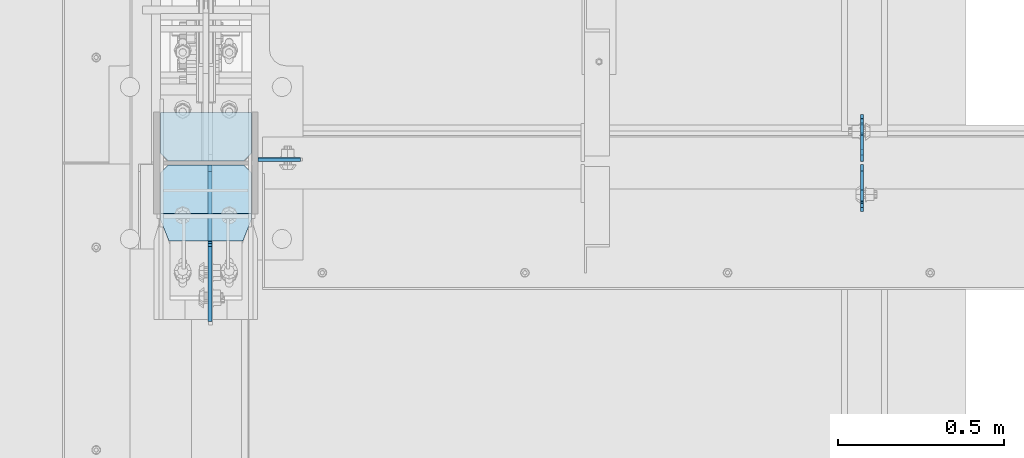
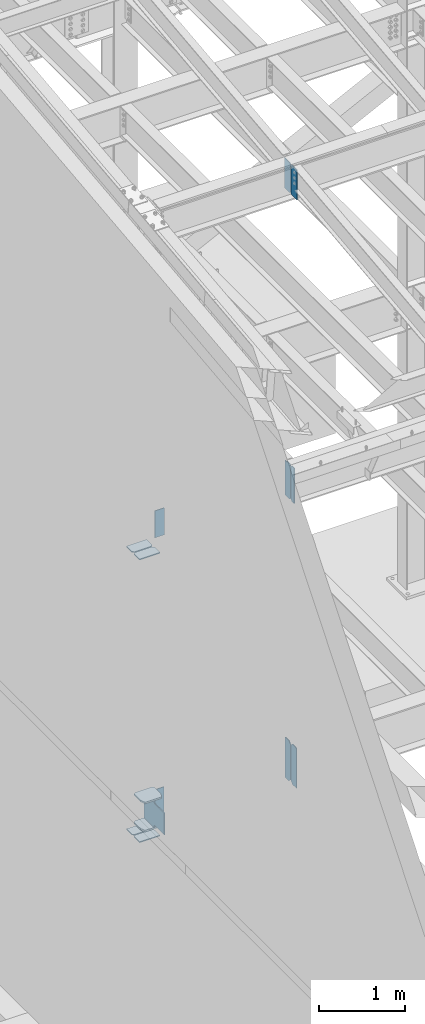
# One storey, part 1022 of 1179: 15 plates, 4 elements without a shape of their own.
"""IFC2X3 building model written with IfcOpenShell, lengths in millimetres."""

from ifc_helpers import new_model, si_unit, frame, origin_with_axes, place, context, subcontext, project, spatial, faceted_brep, material, type_object, element, aggregate, save


model = new_model("IFC2X3")

# Units and contexts
model_context = context("Model", 3, precision=1e-05, world=origin_with_axes())
body_context = subcontext(model_context, "Body", "Model", "MODEL_VIEW")
ifc_project = project(units=[si_unit("LENGTHUNIT", "METRE", prefix="MILLI"), si_unit("AREAUNIT", "SQUARE_METRE"), si_unit("VOLUMEUNIT", "CUBIC_METRE"), si_unit("MASSUNIT", "GRAM", prefix="KILO"), si_unit("TIMEUNIT", "SECOND"), si_unit("PLANEANGLEUNIT", "RADIAN"), si_unit("SOLIDANGLEUNIT", "STERADIAN"), si_unit("THERMODYNAMICTEMPERATUREUNIT", "DEGREE_CELSIUS"), si_unit("LUMINOUSINTENSITYUNIT", "LUMEN")], contexts=[model_context])

# Site, building, storey
site_placement = place(None, origin_with_axes())
site = spatial("IfcSite", under=ifc_project, at=site_placement, CompositionType="ELEMENT")
building_placement = place(site_placement, origin_with_axes())
building = spatial("IfcBuilding", under=site, at=building_placement, Name="Undefined", CompositionType="ELEMENT")
storey_placement = place(building_placement, origin_with_axes())
storey = spatial("IfcBuildingStorey", under=building, at=storey_placement, Name="Undefined", CompositionType="ELEMENT", Elevation=0.0)

# Assembly, plate
assembly_1_placement = place(storey_placement, origin_with_axes())
assembly_1 = element("IfcElementAssembly", 1, at=assembly_1_placement, inside=storey, Name="BEAM", AssemblyPlace="NOTDEFINED", PredefinedType="RIGID_FRAME")
ifc_material_1 = material(Name="STEEL/A36")
plate_type_1 = type_object("IfcPlateType", PredefinedType="NOTDEFINED")
plate_1_placement = place(assembly_1_placement, frame((2405.06200008392, 27055.7625, 7497.7625), z_axis=(0.0, 0.0, 1.0), x_axis=(0.0, 1.0, 0.0)))
plate_1 = element("IfcPlate", 2, at=plate_1_placement, type_object=plate_type_1, material=ifc_material_1, Name="PLATE", context=body_context, shape_type="Brep", body=[
    faceted_brep([(77.7874999999985, -4.76250000000073, 498.475), (77.7874999999985, -4.76250000000073, 496.887499809264), (77.7874999999985, 4.76250000000073, 496.887499809264), (77.7874999999985, 4.76250000000073, 498.475), (78.7542299225861, -4.76250000000073, 492.027420291219), (78.7542299225861, 4.76250000000073, 492.027420291219), (81.5072438230636, -4.76250000000073, 487.907243823065), (81.5072438230636, 4.76250000000073, 487.907243823065), (85.6274202912173, -4.76250000000073, 485.154229922587), (85.6274202912173, 4.76250000000073, 485.154229922587), (90.4874998092637, -4.76250000000073, 484.187499999999), (90.4874998092637, 4.76250000000073, 484.187499999999), (127.000006866454, -4.76249999999982, 484.1875), (127.000004873051, 4.76249999999982, 484.1875), (0.0, -4.76250000000073, 479.425006866455), (19.0499992370605, -4.76250000000073, 498.475006103516), (19.0499992370605, 4.76250000000073, 498.475006103516), (0.0, 4.76250000000073, 479.425006866455), (0.0, -4.76250000000073, 19.0499992370605), (0.0, 4.76250000000073, 19.0499992370605), (19.0499992370605, -4.76250000000073, 0.0), (19.0499992370605, 4.76250000000073, 0.0), (127.0, -4.76250000000073, 0.0), (127.0, 4.76250000000073, 0.0)], [[[0, 1, 2, 3]], [[4, 5, 2, 1]], [[6, 7, 5, 4]], [[8, 9, 7, 6]], [[10, 11, 9, 8]], [[12, 13, 11, 10]], [[14, 15, 16, 17]], [[18, 14, 17, 19]], [[20, 18, 19, 21]], [[22, 20, 21, 23]], [[8, 6, 4, 1, 0, 15, 14, 18, 20, 22, 12, 10]], [[16, 15, 0, 3]], [[23, 21, 19, 17, 16, 3, 2, 5, 7, 9, 11, 13]], [[22, 23, 13, 12]]]),
])

# Assembly, plates
assembly_2_placement = place(storey_placement, origin_with_axes())
assembly_2 = element("IfcElementAssembly", 3, at=assembly_2_placement, inside=storey, Name="COLUMN", AssemblyPlace="NOTDEFINED", PredefinedType="RIGID_FRAME")
plate_2_placement = place(assembly_2_placement, frame((588.962500000001, 27060.525, 7975.6), z_axis=(1.0, 0.0, 0.0), x_axis=(0.0, 0.0, -1.0)))
plate_2 = element("IfcPlate", 4, at=plate_2_placement, type_object=plate_type_1, material=ifc_material_1, Name="PLATE", context=body_context, shape_type="Brep", body=[
    faceted_brep([(0.0, -4.76249999999709, 0.0), (0.0, -4.76249999999709, 127.0), (0.0, 4.76249999999709, 127.0), (0.0, 4.76249999999709, 0.0), (381.0, -4.76249999999709, 127.0), (381.0, 4.76249999999709, 127.0), (381.0, -4.76249999999999, 8.66293703438714e-11), (381.0, 4.76249999999999, 8.66293703438714e-11)], [[[0, 1, 2, 3]], [[1, 4, 5, 2]], [[4, 6, 7, 5]], [[6, 0, 3, 7]], [[5, 7, 3, 2]], [[6, 4, 1, 0]]]),
])
plate_3_placement = place(assembly_2_placement, frame((588.962500000001, 27062.1125, 4038.6), z_axis=(1.0, 0.0, 0.0), x_axis=(0.0, 0.0, -1.0)))
plate_3 = element("IfcPlate", 5, at=plate_3_placement, type_object=plate_type_1, material=ifc_material_1, Name="PLATE", context=body_context, shape_type="Brep", body=[
    faceted_brep([(0.0, -4.76249999999709, 0.0), (0.0, -4.76249999999709, 127.0), (0.0, 4.76249999999709, 127.0), (0.0, 4.76249999999709, 0.0), (457.200012207031, -4.76250000000073, 127.0), (457.200012207031, 4.76250000000073, 127.0), (457.200012207031, -4.76250000000073, 0.0), (457.200012207031, 4.76250000000073, 0.0)], [[[0, 1, 2, 3]], [[1, 4, 5, 2]], [[4, 6, 7, 5]], [[6, 0, 3, 7]], [[5, 7, 3, 2]], [[6, 4, 1, 0]]]),
])

assembly_3_placement = place(storey_placement, origin_with_axes())
assembly_3 = element("IfcElementAssembly", 6, at=assembly_3_placement, inside=storey, Name="BEAM", AssemblyPlace="NOTDEFINED", PredefinedType="RIGID_FRAME")
plate_4_placement = place(assembly_3_placement, frame((2405.06185359955, 27044.65, 3509.9625), z_axis=(0.0, 0.0, 1.0), x_axis=(0.0, -1.0, 0.0)))
plate_4 = element("IfcPlate", 7, at=plate_4_placement, type_object=plate_type_1, material=ifc_material_1, Name="PLATE", context=body_context, shape_type="Brep", body=[
    faceted_brep([(108.916729922588, -4.76250000000073, 568.227420481955), (108.916729922588, 4.76250000000073, 568.227420481955), (108.265773383217, 4.76250000000073, 571.5), (108.265773383217, -4.76250000000073, 571.5), (111.669743823066, -4.76250000000073, 564.107244013801), (111.669743823066, 4.76250000000073, 564.107244013801), (115.789920291219, -4.76250000000073, 561.354230113323), (115.789920291219, 4.76250000000073, 561.354230113323), (120.649999809266, -4.76250000000073, 560.387500190735), (120.649999809266, 4.76250000000073, 560.387500190735), (127.000006866456, -4.76250000000073, 560.387500190735), (127.000004873054, 4.76250000000073, 560.387500190735), (0.0, -4.76250000000073, 536.575000762939), (34.9249992370605, -4.76250000000073, 571.5), (34.9249992370605, 4.76250000000073, 571.5), (0.0, 4.76250000000073, 536.575000762939), (0.0, -4.76250000000073, 34.9249999999993), (0.0, 4.76250000000073, 34.9249999999993), (34.9249992370715, -4.76249999996799, 0.0), (34.9249992370678, 4.76250000003347, 0.0), (127.0, -4.76250000000073, 0.0), (127.0, 4.76250000000073, 0.0)], [[[0, 1, 2, 3]], [[4, 5, 1, 0]], [[6, 7, 5, 4]], [[8, 9, 7, 6]], [[10, 11, 9, 8]], [[12, 13, 14, 15]], [[16, 12, 15, 17]], [[18, 16, 17, 19]], [[20, 18, 19, 21]], [[6, 4, 0, 3, 13, 12, 16, 18, 20, 10, 8]], [[14, 13, 3, 2]], [[21, 19, 17, 15, 14, 2, 1, 5, 7, 9, 11]], [[20, 21, 11, 10]]]),
])
plate_5_placement = place(assembly_3_placement, frame((2405.06185359955, 27057.35, 3509.9625), z_axis=(0.0, 0.0, 1.0), x_axis=(0.0, 1.0, 0.0)))
plate_5 = element("IfcPlate", 8, at=plate_5_placement, type_object=plate_type_1, material=ifc_material_1, Name="PLATE", context=body_context, shape_type="Brep", body=[
    faceted_brep([(108.916729922588, -4.76250000000073, 568.227420481955), (108.916729922588, 4.76250000000073, 568.227420481955), (108.265773383217, 4.76250000000073, 571.5), (108.265773383217, -4.76250000000073, 571.5), (111.669743823066, -4.76250000000073, 564.107244013801), (111.669743823066, 4.76250000000073, 564.107244013801), (115.789920291219, -4.76250000000073, 561.354230113323), (115.789920291219, 4.76250000000073, 561.354230113323), (120.649999809266, -4.76250000000073, 560.387500190735), (120.649999809266, 4.76250000000073, 560.387500190735), (127.000006866456, -4.76250000000073, 560.387500190735), (127.000004873054, 4.76250000000073, 560.387500190735), (0.0, -4.76250000000073, 536.575000762939), (34.9249992370605, -4.76250000000073, 571.5), (34.9249992370605, 4.76250000000073, 571.5), (0.0, 4.76250000000073, 536.575000762939), (0.0, -4.76250000000073, 34.9249999999993), (0.0, 4.76250000000073, 34.9249999999993), (34.9249992370715, -4.76249999996799, 0.0), (34.9249992370678, 4.76250000003347, 0.0), (127.0, -4.76250000000073, 0.0), (127.0, 4.76250000000073, 0.0)], [[[0, 1, 2, 3]], [[4, 5, 1, 0]], [[6, 7, 5, 4]], [[8, 9, 7, 6]], [[10, 11, 9, 8]], [[12, 13, 14, 15]], [[16, 12, 15, 17]], [[18, 16, 17, 19]], [[20, 18, 19, 21]], [[6, 4, 0, 3, 13, 12, 16, 18, 20, 10, 8]], [[14, 13, 3, 2]], [[21, 19, 17, 15, 14, 2, 1, 5, 7, 9, 11]], [[20, 21, 11, 10]]]),
])
aggregate(assembly_3, [plate_4, plate_5])

# Plate
plate_type_2 = type_object("IfcPlateType", PredefinedType="NOTDEFINED")
plate_6_placement = place(assembly_1_placement, frame((2405.06200008392, 27046.2375, 7497.7625), z_axis=(0.0, 0.0, 1.0), x_axis=(0.0, -1.0, 0.0)))
plate_6 = element("IfcPlate", 9, at=plate_6_placement, type_object=plate_type_2, material=ifc_material_1, Name="PLATE", context=body_context, shape_type="Brep", body=[
    faceted_brep([(0.0, -4.76250000000073, 19.0499992370605), (0.0, -4.76250000000073, 479.425006866455), (0.0, 4.76250000000073, 479.425006866455), (0.0, 4.76250000000073, 19.0499992370605), (19.0499992370605, -4.76250000000073, 498.475006103516), (19.0499992370605, 4.76250000000073, 498.475006103516), (76.1999969482422, -4.76250000000073, 498.475006103516), (76.1999969482422, 4.76250000000073, 498.475006103516), (76.1999999999971, -4.76249999999999, 0.0), (76.1999999999971, 4.76249999999999, 0.0), (19.0499992370605, -4.76250000000073, 0.0), (19.0499992370605, 4.76250000000073, 0.0)], [[[0, 1, 2, 3]], [[1, 4, 5, 2]], [[4, 6, 7, 5]], [[6, 8, 9, 7]], [[8, 10, 11, 9]], [[10, 0, 3, 11]], [[5, 7, 9, 11, 3, 2]], [[10, 8, 6, 4, 1, 0]]]),
])

aggregate(assembly_1, [plate_6, plate_1])

# Assembly, plates
assembly_4_placement = place(storey_placement, origin_with_axes())
assembly_4 = element("IfcElementAssembly", 10, at=assembly_4_placement, inside=storey, Name="BEAM", AssemblyPlace="NOTDEFINED", PredefinedType="RIGID_FRAME")
plate_type_3 = type_object("IfcPlateType", PredefinedType="NOTDEFINED")
plate_7_placement = place(assembly_4_placement, frame((2405.06200008392, 27045.4437499701, 11823.3031250357), z_axis=(0.0, 0.0, 1.0), x_axis=(0.0, -1.0, 0.0)))
plate_7 = element("IfcPlate", 11, at=plate_7_placement, type_object=plate_type_3, material=ifc_material_1, Name="PLATE", context=body_context, shape_type="Brep", body=[
    faceted_brep([(-1.81898940354586e-12, -4.76249999999345, 17.4624996185303), (0.0, -4.76250000000073, 407.98750038147), (0.0, 4.76250000000073, 407.98750038147), (1.81898940354586e-12, 4.76250000000073, 17.4624996185303), (17.4624996185303, -4.76250000000073, 425.450000000001), (17.4624996185303, 4.76250000000073, 425.450000000001), (139.699999999997, -4.76250000000073, 425.450000000001), (139.699999999997, 4.76250000000073, 425.450000000001), (139.7, -4.76249999999982, 0.0), (139.7, 4.76249999999982, 0.0), (17.4624996185157, -4.76250000000073, 0.0), (17.4624996185212, 4.76249999999345, 0.0)], [[[0, 1, 2, 3]], [[1, 4, 5, 2]], [[4, 6, 7, 5]], [[6, 8, 9, 7]], [[8, 10, 11, 9]], [[10, 0, 3, 11]], [[5, 7, 9, 11, 3, 2]], [[10, 8, 6, 4, 1, 0]]]),
])
plate_8_placement = place(assembly_4_placement, frame((2405.06200008392, 27056.5562499701, 11823.3031250357), z_axis=(0.0, 0.0, 1.0), x_axis=(0.0, 1.0, 0.0)))
plate_8 = element("IfcPlate", 12, at=plate_8_placement, type_object=plate_type_3, material=ifc_material_1, Name="PLATE", context=body_context, shape_type="Brep", body=[
    faceted_brep([(-1.81898940354586e-12, -4.76249999999345, 17.4624996185303), (0.0, -4.76250000000073, 407.98750038147), (0.0, 4.76250000000073, 407.98750038147), (1.81898940354586e-12, 4.76250000000073, 17.4624996185303), (17.4624996185303, -4.76250000000073, 425.450000000001), (17.4624996185303, 4.76250000000073, 425.450000000001), (139.699999999997, -4.76250000000073, 425.450000000001), (139.699999999997, 4.76250000000073, 425.450000000001), (139.7, -4.76249999999982, 0.0), (139.7, 4.76249999999982, 0.0), (17.4624996185157, -4.76250000000073, 0.0), (17.4624996185212, 4.76249999999345, 0.0)], [[[0, 1, 2, 3]], [[1, 4, 5, 2]], [[4, 6, 7, 5]], [[6, 8, 9, 7]], [[8, 10, 11, 9]], [[10, 0, 3, 11]], [[5, 7, 9, 11, 3, 2]], [[10, 8, 6, 4, 1, 0]]]),
])
aggregate(assembly_4, [plate_7, plate_8])

# Plate
ifc_material_2 = material(Name="STEEL/A572-GR.50")
plate_type_4 = type_object("IfcPlateType", PredefinedType="NOTDEFINED")
plate_9_placement = place(assembly_2_placement, frame((295.274999999998, 26816.05, 3694.1125), z_axis=(1.0, 0.0, 0.0), x_axis=(0.0, 1.0, 0.0)))
plate_9 = element("IfcPlate", 13, at=plate_9_placement, type_object=plate_type_4, material=ifc_material_2, Name="PLATE", context=body_context, shape_type="Brep", body=[
    faceted_brep([(0.0, -11.1125000000002, 247.650000381473), (63.5, -11.1125000000002, 273.050000000003), (63.5, 11.1125000000002, 273.050000000003), (0.0, 11.1125000000002, 247.650000381473), (63.5, -11.1125000000002, 0.0), (0.0, -11.1125000000002, 25.3999996185303), (0.0, 11.1125000000002, 25.3999996185303), (63.5, 11.1125000000002, 0.0), (206.374999618529, -11.1125000000002, 0.0), (206.374999618529, 11.1125000000002, 0.0), (228.599999999999, -11.1125000000002, 22.2250003814697), (228.599999999999, 11.1125000000002, 22.2250003814697), (228.599999999999, -11.1125000000002, 250.824999618533), (228.599999999999, 11.1125000000002, 250.824999618533), (206.374999618529, -11.1125000000002, 273.050000000003), (206.374999618529, 11.1125000000002, 273.050000000003)], [[[0, 1, 2, 3]], [[4, 5, 6, 7]], [[8, 4, 7, 9]], [[10, 8, 9, 11]], [[12, 10, 11, 13]], [[14, 12, 13, 15]], [[4, 8, 10, 12, 14, 1, 0, 5]], [[5, 0, 3, 6]], [[2, 15, 13, 11, 9, 7, 6, 3]], [[1, 14, 15, 2]]]),
])

plate_10_placement = place(assembly_2_placement, frame((295.274999999998, 26816.05, 4090.9875), z_axis=(1.0, 0.0, 0.0), x_axis=(0.0, 1.0, 0.0)))
plate_10 = element("IfcPlate", 14, at=plate_10_placement, type_object=plate_type_4, material=ifc_material_2, Name="PLATE", context=body_context, shape_type="Brep", body=[
    faceted_brep([(0.0, -11.1125000000002, 247.650000381473), (63.5, -11.1125000000002, 273.050000000003), (63.5, 11.1125000000002, 273.050000000003), (0.0, 11.1125000000002, 247.650000381473), (63.5, -11.1125000000002, 0.0), (0.0, -11.1125000000002, 25.3999996185303), (0.0, 11.1125000000002, 25.3999996185303), (63.5, 11.1125000000002, 0.0), (206.374999618529, -11.1125000000002, 0.0), (206.374999618529, 11.1125000000002, 0.0), (228.599999999999, -11.1125000000002, 22.2250003814697), (228.599999999999, 11.1125000000002, 22.2250003814697), (228.599999999999, -11.1125000000002, 250.824999618533), (228.599999999999, 11.1125000000002, 250.824999618533), (206.374999618529, -11.1125000000002, 273.050000000003), (206.374999618529, 11.1125000000002, 273.050000000003)], [[[0, 1, 2, 3]], [[4, 5, 6, 7]], [[8, 4, 7, 9]], [[10, 8, 9, 11]], [[12, 10, 11, 13]], [[14, 12, 13, 15]], [[4, 8, 10, 12, 14, 1, 0, 5]], [[5, 0, 3, 6]], [[2, 15, 13, 11, 9, 7, 6, 3]], [[1, 14, 15, 2]]]),
])

plate_type_5 = type_object("IfcPlateType", PredefinedType="NOTDEFINED")
plate_11_placement = place(assembly_2_placement, frame((568.325000000001, 27044.65, 7486.65), z_axis=(-1.0, 0.0, 0.0), x_axis=(0.0, -1.0, 0.0)))
plate_11 = element("IfcPlate", 15, at=plate_11_placement, type_object=plate_type_5, material=ifc_material_1, Name="PLATE", context=body_context, shape_type="Brep", body=[
    faceted_brep([(0.0, -6.34999999999854, 22.2250003814697), (0.0, -6.35000000000036, 250.82499961853), (0.0, 6.35000000000036, 250.82499961853), (0.0, 6.34999999999854, 22.2250003814697), (22.2250003814697, -6.35000000000036, 273.05), (22.2250003814697, 6.35000000000036, 273.05), (146.050003051758, -6.35000000000036, 273.049987792969), (146.050003051758, 6.35000000000036, 273.049987792969), (146.050003051758, -6.35000000000036, 0.0), (146.050003051758, 6.35000000000036, 0.0), (22.2250003814697, -6.34999999999854, 0.0), (22.2250003814697, 6.34999999999854, 0.0)], [[[0, 1, 2, 3]], [[1, 4, 5, 2]], [[4, 6, 7, 5]], [[6, 8, 9, 7]], [[8, 10, 11, 9]], [[10, 0, 3, 11]], [[5, 7, 9, 11, 3, 2]], [[10, 8, 6, 4, 1, 0]]]),
])

plate_12_placement = place(assembly_2_placement, frame((568.325000000001, 27203.4, 7486.65), z_axis=(-1.0, 0.0, 0.0), x_axis=(0.0, -1.0, 0.0)))
plate_12 = element("IfcPlate", 16, at=plate_12_placement, type_object=plate_type_5, material=ifc_material_1, Name="PLATE", context=body_context, shape_type="Brep", body=[
    faceted_brep([(0.0, -6.34999999999854, 0.0), (0.0, -6.34999999999991, 273.05), (0.0, 6.34999999999991, 273.05), (0.0, 6.34999999999854, 0.0), (123.824999618599, -6.34999999999991, 273.05), (123.824999618599, 6.34999999999991, 273.05), (146.050000000068, -6.34999999999991, 250.82499961853), (146.050000000068, 6.34999999999991, 250.82499961853), (146.050000000068, -6.34999999999991, 22.2250003814697), (146.050000000068, 6.34999999999991, 22.2250003814697), (123.824999618599, -6.34999999999991, 0.0), (123.824999618599, 6.34999999999991, 0.0)], [[[0, 1, 2, 3]], [[1, 4, 5, 2]], [[4, 6, 7, 5]], [[6, 8, 9, 7]], [[8, 10, 11, 9]], [[10, 0, 3, 11]], [[5, 7, 9, 11, 3, 2]], [[10, 8, 6, 4, 1, 0]]]),
])

plate_13_placement = place(assembly_2_placement, frame((568.325000000001, 27044.65, 3495.675), z_axis=(-1.0, 0.0, 0.0), x_axis=(0.0, -1.0, 0.0)))
plate_13 = element("IfcPlate", 17, at=plate_13_placement, type_object=plate_type_5, material=ifc_material_1, Name="PLATE", context=body_context, shape_type="Brep", body=[
    faceted_brep([(0.0, -6.34999999999854, 22.2250003814697), (0.0, -6.35000000000036, 250.82499961853), (0.0, 6.35000000000036, 250.82499961853), (0.0, 6.34999999999854, 22.2250003814697), (22.2250003814697, -6.35000000000036, 273.05), (22.2250003814697, 6.35000000000036, 273.05), (146.050003051758, -6.35000000000036, 273.049987792969), (146.050003051758, 6.35000000000036, 273.049987792969), (146.050003051758, -6.35000000000036, 0.0), (146.050003051758, 6.35000000000036, 0.0), (22.2250003814697, -6.34999999999854, 0.0), (22.2250003814697, 6.34999999999854, 0.0)], [[[0, 1, 2, 3]], [[1, 4, 5, 2]], [[4, 6, 7, 5]], [[6, 8, 9, 7]], [[8, 10, 11, 9]], [[10, 0, 3, 11]], [[5, 7, 9, 11, 3, 2]], [[10, 8, 6, 4, 1, 0]]]),
])

plate_14_placement = place(assembly_2_placement, frame((568.325000000001, 27203.4, 3495.675), z_axis=(-1.0, 0.0, 0.0), x_axis=(0.0, -1.0, 0.0)))
plate_14 = element("IfcPlate", 18, at=plate_14_placement, type_object=plate_type_5, material=ifc_material_1, Name="PLATE", context=body_context, shape_type="Brep", body=[
    faceted_brep([(0.0, -6.34999999999854, 0.0), (0.0, -6.34999999999991, 273.05), (0.0, 6.34999999999991, 273.05), (0.0, 6.34999999999854, 0.0), (123.824999618599, -6.34999999999991, 273.05), (123.824999618599, 6.34999999999991, 273.05), (146.050000000068, -6.34999999999991, 250.82499961853), (146.050000000068, 6.34999999999991, 250.82499961853), (146.050000000068, -6.34999999999991, 22.2250003814697), (146.050000000068, 6.34999999999991, 22.2250003814697), (123.824999618599, -6.34999999999991, 0.0), (123.824999618599, 6.34999999999991, 0.0)], [[[0, 1, 2, 3]], [[1, 4, 5, 2]], [[4, 6, 7, 5]], [[6, 8, 9, 7]], [[8, 10, 11, 9]], [[10, 0, 3, 11]], [[5, 7, 9, 11, 3, 2]], [[10, 8, 6, 4, 1, 0]]]),
])

plate_type_6 = type_object("IfcPlateType", PredefinedType="NOTDEFINED")
plate_15_placement = place(assembly_2_placement, frame((443.706250000002, 27044.6499999542, 3724.275), z_axis=(0.0, -0.707106781186506, 0.707106781186589), x_axis=(0.0, -0.70710678118659, -0.707106781186505)))
plate_15 = element("IfcPlate", 19, at=plate_15_placement, type_object=plate_type_6, material=ifc_material_2, Name="PLATE", context=body_context, shape_type="Brep", body=[
    faceted_brep([(0.0, -6.34999999999854, 0.0), (-237.976787208419, -6.34999999999854, 237.976787208414), (-237.976787208419, 6.34999999999854, 237.976787208414), (0.0, 6.34999999999854, 0.0), (-237.976787208489, -6.34999999999854, 264.917555571561), (-237.976787208489, 6.34999999999854, 264.917555571561), (-89.8025612115634, -6.34999999999854, 413.09178156849), (-89.8025612115634, 6.34999999999854, 413.09178156849), (-87.5574986365136, -6.35000000000002, 410.846713673389), (-87.5574986365136, 6.35000000000002, 410.846713673389), (-79.3171439752477, -6.34999999999854, 405.340689467515), (-79.3171439752477, 6.34999999999854, 405.340689467515), (-69.5969849391658, -6.34999999999854, 403.407229622333), (-69.5969849391658, 6.34999999999854, 403.407229622333), (-59.8768259030876, -6.34999999999854, 405.340689467494), (-59.8768259030876, 6.34999999999854, 405.340689467494), (-51.6364729667966, -6.34999999999854, 410.84671726843), (-51.6364729667966, 6.34999999999854, 410.84671726843), (101.027881360342, -6.34999999999854, 563.511071595573), (101.027881360342, 6.34999999999854, 563.511071595573), (316.554028266077, -6.34999999999854, 347.984924689843), (316.554028266077, 6.34999999999854, 347.984924689843), (163.889673938938, -6.34999999999854, 195.320570362701), (163.889673938938, 6.34999999999854, 195.320570362701), (158.383646138001, -6.34999999999854, 187.080217426408), (158.383646138001, 6.34999999999854, 187.080217426408), (156.450186292839, -6.34999999999854, 177.360058390334), (156.450186292839, 6.34999999999854, 177.360058390334), (158.383646138027, -6.34999999999854, 167.639899354248), (158.383646138027, 6.34999999999854, 167.639899354248), (163.889673938986, -6.34999999999854, 159.399546417944), (163.889673938986, 6.34999999999854, 159.399546417944), (175.114994360907, -6.34999999999854, 148.174225997692), (175.114994360907, 6.34999999999854, 148.174225997692), (26.9407683631471, -6.34999999999854, -6.91215973347425e-11), (26.9407683631471, 6.34999999999854, -6.91215973347425e-11)], [[[0, 1, 2, 3]], [[1, 4, 5, 2]], [[4, 6, 7, 5]], [[6, 8, 9, 7]], [[8, 10, 11, 9]], [[10, 12, 13, 11]], [[12, 14, 15, 13]], [[14, 16, 17, 15]], [[16, 18, 19, 17]], [[18, 20, 21, 19]], [[20, 22, 23, 21]], [[22, 24, 25, 23]], [[24, 26, 27, 25]], [[26, 28, 29, 27]], [[28, 30, 31, 29]], [[30, 32, 33, 31]], [[32, 34, 35, 33]], [[34, 0, 3, 35]], [[5, 7, 9, 11, 13, 15, 17, 19, 21, 23, 25, 27, 29, 31, 33, 35, 3, 2]], [[34, 32, 30, 28, 26, 24, 22, 20, 18, 16, 14, 12, 10, 8, 6, 4, 1, 0]]]),
])

aggregate(assembly_2, [plate_11, plate_12, plate_2, plate_9, plate_10, plate_15, plate_13, plate_14, plate_3])

save(model, "model.ifc")
